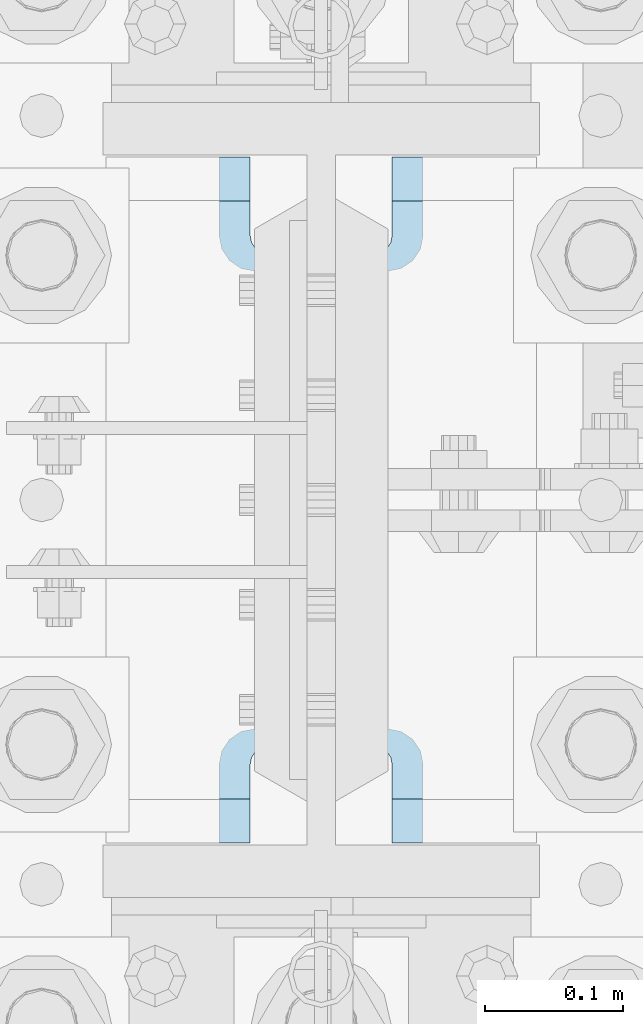
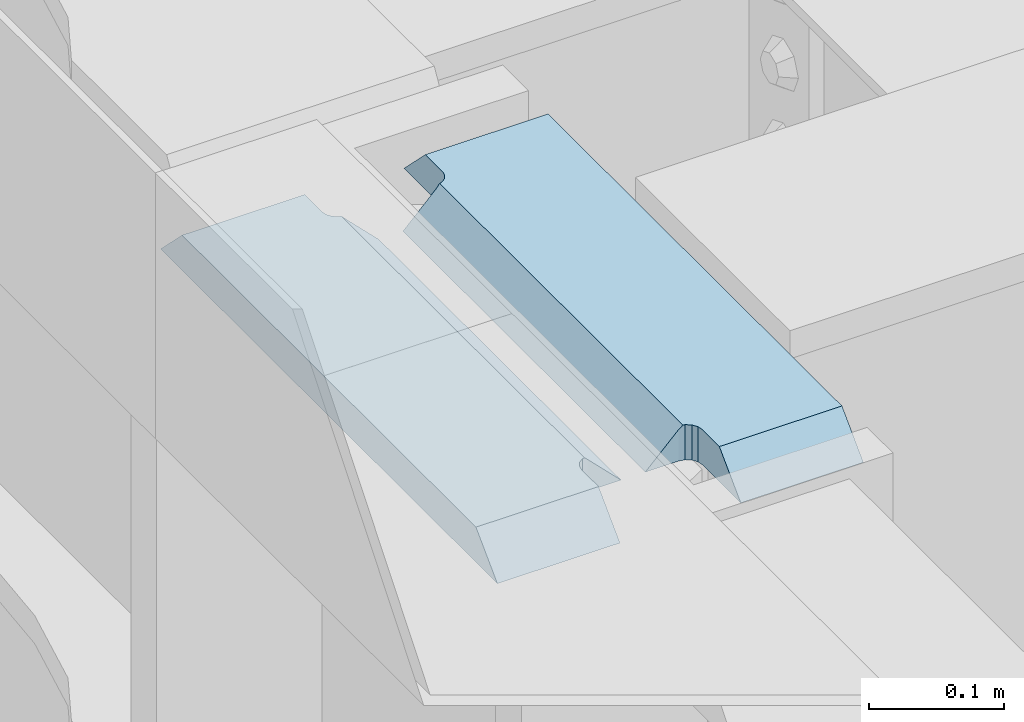
# One storey, part 1552 of 1876: 2 plates, 1 element without a shape of its own.
"""IFC2X3 building model written with IfcOpenShell, lengths in millimetres."""

from ifc_helpers import new_model, si_unit, frame, origin_with_axes, place, context, subcontext, project, spatial, faceted_brep, material, type_object, element, aggregate, save


model = new_model("IFC2X3")

# Units and contexts
model_context = context("Model", 3, precision=1e-05, world=origin_with_axes())
body_context = subcontext(model_context, "Body", "Model", "MODEL_VIEW")
ifc_project = project(units=[si_unit("LENGTHUNIT", "METRE", prefix="MILLI"), si_unit("AREAUNIT", "SQUARE_METRE"), si_unit("VOLUMEUNIT", "CUBIC_METRE"), si_unit("MASSUNIT", "GRAM", prefix="KILO"), si_unit("TIMEUNIT", "SECOND"), si_unit("PLANEANGLEUNIT", "RADIAN"), si_unit("SOLIDANGLEUNIT", "STERADIAN"), si_unit("THERMODYNAMICTEMPERATUREUNIT", "DEGREE_CELSIUS"), si_unit("LUMINOUSINTENSITYUNIT", "LUMEN")], contexts=[model_context])

# Site, building, storey
site_placement = place(None, origin_with_axes())
site = spatial("IfcSite", under=ifc_project, at=site_placement, CompositionType="ELEMENT")
building_placement = place(site_placement, origin_with_axes())
building = spatial("IfcBuilding", under=site, at=building_placement, Name="Undefined", CompositionType="ELEMENT")
storey_placement = place(building_placement, origin_with_axes())
storey = spatial("IfcBuildingStorey", under=building, at=storey_placement, Name="Undefined", CompositionType="ELEMENT", Elevation=0.0)

# Assembly, plates
assembly_placement = place(storey_placement, origin_with_axes())
assembly = element("IfcElementAssembly", 1, at=assembly_placement, inside=storey, Name="COLUMN", AssemblyPlace="NOTDEFINED", PredefinedType="RIGID_FRAME")
ifc_material = material(Name="STEEL/A572-50")
plate_type = type_object("IfcPlateType", PredefinedType="NOTDEFINED")
plate_1_placement = place(assembly_placement, frame((-156.36875, 1274.7625, 22539.325), z_axis=(0.0, 1.0, 0.0), x_axis=(1.0, 0.0, 0.0)))
plate_1 = element("IfcPlate", 2, at=plate_1_placement, type_object=plate_type, material=ifc_material, Name="PLATE", context=body_context, shape_type="Brep", body=[
    faceted_brep([(108.494745348945, -15.875, 66.1302546510551), (108.494745348945, 15.875, 66.1302546510551), (112.614921817099, 15.875, 68.8832685515335), (112.614921817099, -15.875, 68.8832685515335), (105.741731448466, -15.875, 62.0100781829015), (105.741731448466, 15.875, 62.0100781829015), (104.775001525879, -15.875, 57.149998664856), (104.775001525879, 15.875, 57.149998664856), (104.775001525879, -15.875, 31.75), (104.775001525879, 15.875, 0.0), (0.0, -15.875, 31.75), (0.0, 15.875, 0.0), (0.0, -15.875, 466.725006103516), (0.0, 15.875, 498.475006103516), (104.775001525879, -15.875, 466.725006103516), (104.775001525879, 15.875, 498.475006103516), (104.775001525879, -15.875, 441.325001335143), (104.775001525879, 15.875, 441.325001335143), (105.741731448466, -15.875, 436.464921817097), (105.741731448466, 15.875, 436.464921817097), (108.494745348945, -15.875, 432.344745348943), (108.494745348945, 15.875, 432.344745348943), (112.614921817099, -15.875, 429.591731448465), (112.614921817099, 15.875, 429.591731448465), (117.475001335144, 15.875, 69.8499984741211), (117.475001335144, 15.875, 428.625001525877), (146.050003051758, 15.875, 428.625001525877), (146.050003051758, 15.875, 69.8499984741211), (117.475001335144, -12.7000017166138, 69.8499984741211), (114.300003051756, -15.875, 69.2184520491464), (114.300003051756, -15.875, 429.256547950852), (117.475001335144, -12.7000017166138, 428.625001525877)], [[[0, 1, 2, 3]], [[4, 5, 1, 0]], [[6, 7, 5, 4]], [[8, 9, 7, 6]], [[10, 11, 9, 8]], [[11, 10, 12, 13]], [[13, 12, 14, 15]], [[15, 14, 16, 17]], [[18, 19, 17, 16]], [[20, 21, 19, 18]], [[22, 23, 21, 20]], [[24, 2, 1, 5, 7, 9, 11, 13, 15, 17, 19, 21, 23, 25, 26, 27]], [[24, 27, 28]], [[3, 2, 24, 28, 29]], [[22, 20, 18, 16, 14, 12, 10, 8, 6, 4, 0, 3, 29, 30]], [[25, 23, 22, 30, 31]], [[25, 31, 26]], [[30, 29, 28, 27, 26, 31]]]),
])
plate_2_placement = place(assembly_placement, frame((156.36875, 1274.7625, 22539.325), z_axis=(0.0, 1.0, 0.0), x_axis=(-1.0, 0.0, 0.0)))
plate_2 = element("IfcPlate", 3, at=plate_2_placement, type_object=plate_type, material=ifc_material, Name="PLATE", context=body_context, shape_type="Brep", body=[
    faceted_brep([(108.494745348945, -15.875, 66.1302546510551), (108.494745348945, 15.875, 66.1302546510551), (112.614921817099, 15.875, 68.8832685515335), (112.614921817099, -15.875, 68.8832685515335), (105.741731448466, -15.875, 62.0100781829015), (105.741731448466, 15.875, 62.0100781829015), (104.775001525879, -15.875, 57.149998664856), (104.775001525879, 15.875, 57.149998664856), (104.775001525879, -15.875, 0.0), (104.775001525879, 15.875, 31.75), (0.0, -15.875, 0.0), (0.0, 15.875, 31.75), (0.0, -15.875, 498.475006103516), (0.0, 15.875, 466.725006103516), (104.775001525879, -15.875, 498.475006103516), (104.775001525879, 15.875, 466.725006103516), (104.775001525879, -15.875, 441.325001335143), (104.775001525879, 15.875, 441.325001335143), (105.741731448466, -15.875, 436.464921817097), (105.741731448466, 15.875, 436.464921817097), (108.494745348945, -15.875, 432.344745348943), (108.494745348945, 15.875, 432.344745348943), (112.614921817099, -15.875, 429.591731448465), (112.614921817099, 15.875, 429.591731448465), (117.475001335144, -15.875, 428.625001525877), (146.050003051758, -15.875, 428.625001525877), (117.475001335144, 12.6999956131003, 428.625001525877), (114.299996948243, 15.875, 429.256549164917), (114.299996948243, 15.875, 69.218450835082), (117.475001335144, -15.875, 69.8499984741211), (117.475001335144, 12.6999956131003, 69.8499984741211), (146.050003051758, -15.875, 69.8499984741211)], [[[0, 1, 2, 3]], [[4, 5, 1, 0]], [[6, 7, 5, 4]], [[8, 9, 7, 6]], [[10, 11, 9, 8]], [[11, 10, 12, 13]], [[13, 12, 14, 15]], [[14, 16, 17, 15]], [[18, 19, 17, 16]], [[20, 21, 19, 18]], [[22, 23, 21, 20]], [[24, 25, 26]], [[23, 22, 24, 26, 27]], [[2, 1, 5, 7, 9, 11, 13, 15, 17, 19, 21, 23, 27, 28]], [[29, 3, 2, 28, 30]], [[29, 30, 31]], [[24, 22, 20, 18, 16, 14, 12, 10, 8, 6, 4, 0, 3, 29, 31, 25]], [[30, 28, 27, 26, 25, 31]]]),
])
aggregate(assembly, [plate_1, plate_2])

save(model, "model.ifc")
